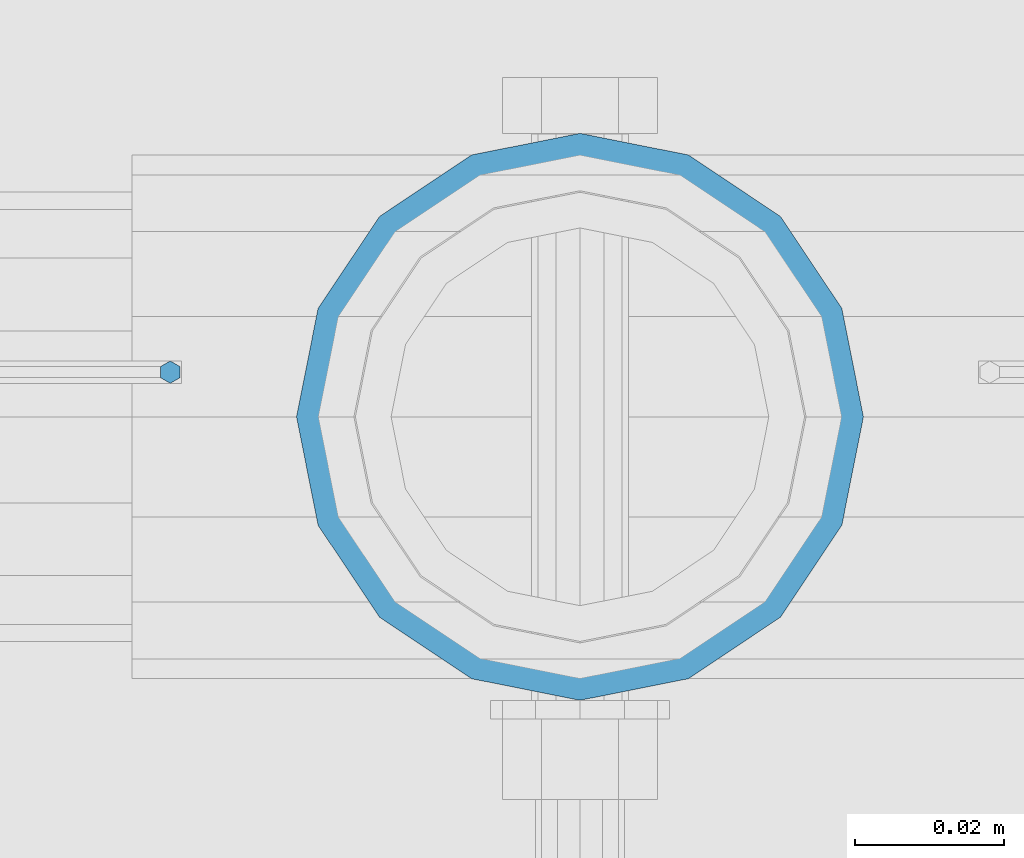
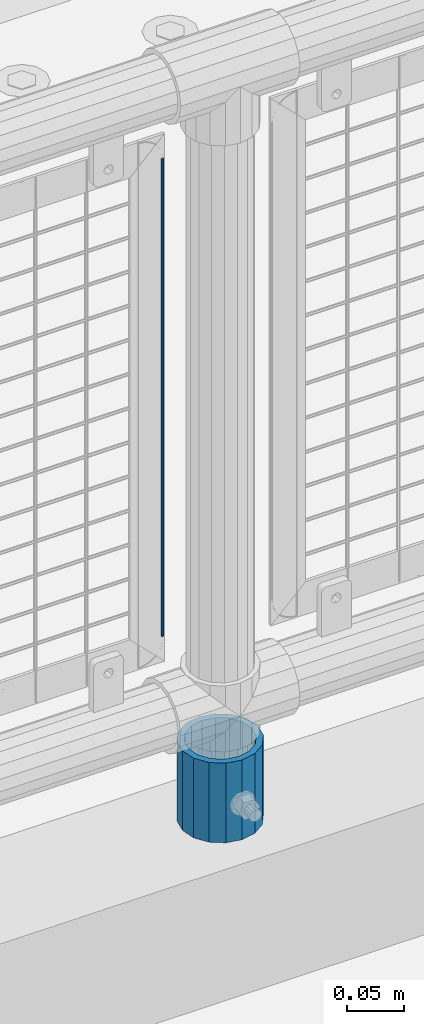
# One storey, part 74 of 240: 2 columns.
"""IFC2X3 building model written with IfcOpenShell, lengths in millimetres."""

from ifc_helpers import new_model, si_unit, frame, origin_with_axes, place, context, subcontext, project, spatial, faceted_brep, material, type_object, element, save


model = new_model("IFC2X3")

# Units and contexts
model_context = context("Model", 3, precision=1e-05, world=origin_with_axes())
body_context = subcontext(model_context, "Body", "Model", "MODEL_VIEW")
ifc_project = project(units=[si_unit("LENGTHUNIT", "METRE", prefix="MILLI"), si_unit("AREAUNIT", "SQUARE_METRE"), si_unit("VOLUMEUNIT", "CUBIC_METRE"), si_unit("MASSUNIT", "GRAM", prefix="KILO"), si_unit("TIMEUNIT", "SECOND"), si_unit("PLANEANGLEUNIT", "RADIAN"), si_unit("SOLIDANGLEUNIT", "STERADIAN"), si_unit("THERMODYNAMICTEMPERATUREUNIT", "DEGREE_CELSIUS"), si_unit("LUMINOUSINTENSITYUNIT", "LUMEN")], contexts=[model_context])

# Site, building, storey
site_placement = place(None, origin_with_axes())
site = spatial("IfcSite", under=ifc_project, at=site_placement, CompositionType="ELEMENT")
building_placement = place(site_placement, origin_with_axes())
building = spatial("IfcBuilding", under=site, at=building_placement, Name="Standard", CompositionType="ELEMENT")
storey_placement = place(building_placement, origin_with_axes())
storey = spatial("IfcBuildingStorey", under=building, at=storey_placement, Name="Undefined", CompositionType="ELEMENT", Elevation=0.0)

# Columns
ifc_material_1 = material(Name="Misc_Undefined")
column_type_1 = type_object("IfcColumnType", Name="D3", PredefinedType="NOTDEFINED")
column_1_placement = place(storey_placement, frame((46332.0, 34670.5, 378.02), z_axis=(-1.0, 0.0, 0.0), x_axis=(0.0, 0.0, 1.0)))
element("IfcColumn", 1, at=column_1_placement, inside=storey, type_object=column_type_1, material=ifc_material_1, ObjectType="D3", context=body_context, shape_type="Brep", body=[
    faceted_brep([(-7.27595761418343e-12, -1.49999999999272, 0.0), (-7.27595761418343e-12, -0.749999999992724, -1.29903810567669), (510.0, -0.75, -1.29903810567339), (510.0, -1.5, 0.0), (0.0, 0.750000000007276, -1.29903810567669), (510.0, 0.75, -1.29903810567339), (0.0, 1.50000000000728, 0.0), (510.0, 1.5, 0.0), (0.0, 0.750000000007276, 1.29903810567669), (510.0, 0.75, 1.29903810567339), (-7.27595761418343e-12, -0.749999999992724, 1.29903810567669), (510.0, -0.75, 1.29903810567339)], [[[0, 1, 2, 3]], [[1, 4, 5, 2]], [[4, 6, 7, 5]], [[6, 8, 9, 7]], [[8, 10, 11, 9]], [[10, 0, 3, 11]], [[5, 7, 9, 11, 3, 2]], [[10, 8, 6, 4, 1, 0]]]),
])
ifc_material_2 = material()
column_type_2 = type_object("IfcColumnType", PredefinedType="NOTDEFINED")
column_2_placement = place(storey_placement, frame((46387.0, 34664.5, 168.02), z_axis=(0.0, 1.0, 0.0), x_axis=(0.0, 0.0, 1.0)))
element("IfcColumn", 2, at=column_2_placement, inside=storey, type_object=column_type_2, material=ifc_material_2, context=body_context, shape_type="Brep", body=[
    faceted_brep([(0.0, -31.75, 0.0), (0.0, -29.3331751572332, 12.1501989775934), (85.0, -29.3331751572332, 12.1501989775934), (85.0, -31.75, 0.0), (0.0, -22.4506403026753, 22.4506403026753), (85.0, -22.4506403026753, 22.4506403026753), (0.0, -12.1501989775934, 29.3331751572332), (85.0, -12.1501989775934, 29.3331751572332), (0.0, 0.0, 31.75), (85.0, 0.0, 31.75), (0.0, 12.1501989775934, 29.3331751572332), (85.0, 12.1501989775934, 29.3331751572332), (0.0, 22.4506403026753, 22.4506403026753), (85.0, 22.4506403026753, 22.4506403026753), (0.0, 29.3331751572332, 12.1501989775934), (85.0, 29.3331751572332, 12.1501989775934), (0.0, 31.75, 0.0), (85.0, 31.75, 0.0), (0.0, 29.3331751572332, -12.1501989775934), (85.0, 29.3331751572332, -12.1501989775934), (0.0, 22.4506403026753, -22.4506403026753), (85.0, 22.4506403026753, -22.4506403026753), (0.0, 12.1501989775934, -29.3331751572332), (85.0, 12.1501989775934, -29.3331751572332), (0.0, 0.0, -31.75), (85.0, 0.0, -31.75), (0.0, -12.1501989775934, -29.3331751572332), (85.0, -12.1501989775934, -29.3331751572332), (0.0, -22.4506403026753, -22.4506403026753), (85.0, -22.4506403026753, -22.4506403026753), (0.0, -29.3331751572332, -12.1501989775934), (85.0, -29.3331751572332, -12.1501989775934), (0.0, -38.0500000000029, 0.0), (0.0, -35.1536162120537, -14.5611046014892), (85.0, -35.1536162120537, -14.5611046014892), (85.0, -38.0500000000029, 0.0), (0.0, -26.9054130241493, -26.9054130241493), (85.0, -26.9054130241493, -26.9054130241493), (0.0, -14.5611046014892, -35.1536162120537), (85.0, -14.5611046014892, -35.1536162120537), (0.0, 0.0, -38.0500000000029), (85.0, 0.0, -38.0500000000029), (0.0, 14.5611046014892, -35.1536162120537), (85.0, 14.5611046014892, -35.1536162120537), (0.0, 26.9054130241493, -26.9054130241493), (85.0, 26.9054130241493, -26.9054130241493), (0.0, 35.1536162120537, -14.5611046014892), (85.0, 35.1536162120537, -14.5611046014892), (0.0, 38.0500000000029, 0.0), (85.0, 38.0500000000029, 0.0), (0.0, 35.1536162120537, 14.5611046014892), (85.0, 35.1536162120537, 14.5611046014892), (0.0, 26.9054130241493, 26.9054130241493), (85.0, 26.9054130241493, 26.9054130241493), (0.0, 14.5611046014892, 35.1536162120537), (85.0, 14.5611046014892, 35.1536162120537), (0.0, 0.0, 38.0500000000029), (85.0, 0.0, 38.0500000000029), (0.0, -14.5611046014892, 35.1536162120537), (85.0, -14.5611046014892, 35.1536162120537), (0.0, -26.9054130241493, 26.9054130241493), (85.0, -26.9054130241493, 26.9054130241493), (0.0, -35.1536162120537, 14.5611046014892), (85.0, -35.1536162120537, 14.5611046014892)], [[[0, 1, 2, 3]], [[1, 4, 5, 2]], [[4, 6, 7, 5]], [[6, 8, 9, 7]], [[8, 10, 11, 9]], [[10, 12, 13, 11]], [[12, 14, 15, 13]], [[14, 16, 17, 15]], [[16, 18, 19, 17]], [[18, 20, 21, 19]], [[20, 22, 23, 21]], [[22, 24, 25, 23]], [[24, 26, 27, 25]], [[26, 28, 29, 27]], [[28, 30, 31, 29]], [[30, 0, 3, 31]], [[32, 33, 34, 35]], [[33, 36, 37, 34]], [[36, 38, 39, 37]], [[38, 40, 41, 39]], [[40, 42, 43, 41]], [[42, 44, 45, 43]], [[44, 46, 47, 45]], [[46, 48, 49, 47]], [[48, 50, 51, 49]], [[50, 52, 53, 51]], [[52, 54, 55, 53]], [[54, 56, 57, 55]], [[56, 58, 59, 57]], [[58, 60, 61, 59]], [[60, 62, 63, 61]], [[62, 32, 35, 63]], [[37, 39, 41, 43, 45, 47, 49, 51, 53, 55, 57, 59, 61, 63, 35, 34], [5, 7, 9, 11, 13, 15, 17, 19, 21, 23, 25, 27, 29, 31, 3, 2]], [[62, 60, 58, 56, 54, 52, 50, 48, 46, 44, 42, 40, 38, 36, 33, 32], [30, 28, 26, 24, 22, 20, 18, 16, 14, 12, 10, 8, 6, 4, 1, 0]]]),
])

save(model, "model.ifc")
